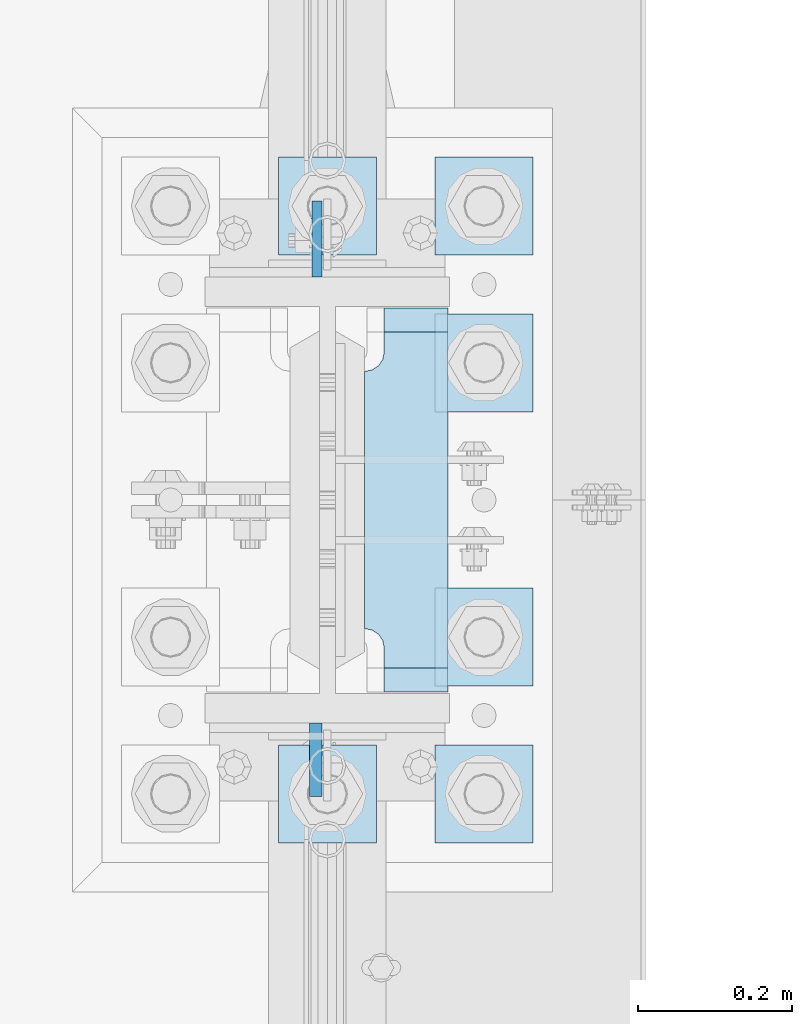
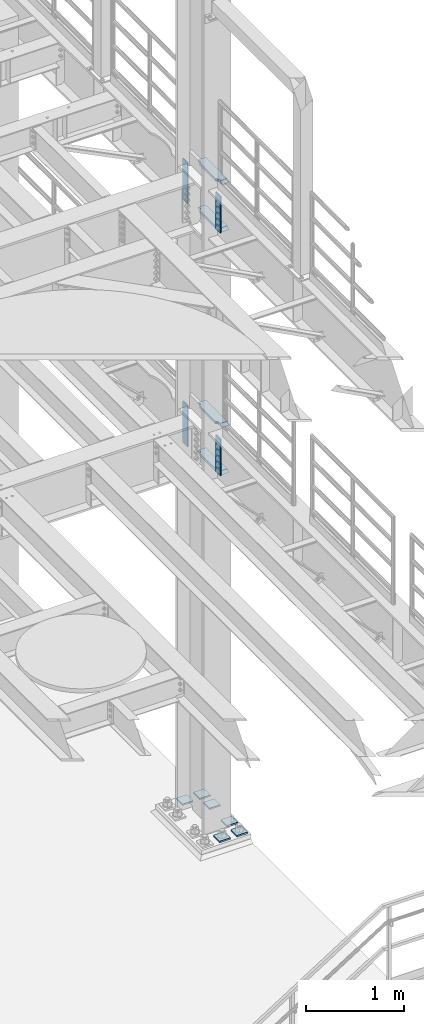
# One storey, part 1676 of 1876: 14 plates, 2 elements without a shape of their own.
"""IFC2X3 building model written with IfcOpenShell, lengths in millimetres."""

from ifc_helpers import new_model, si_unit, frame, origin_with_axes, place, context, subcontext, project, spatial, faceted_brep, material, type_object, element, aggregate, save


model = new_model("IFC2X3")

# Units and contexts
model_context = context("Model", 3, precision=1e-05, world=origin_with_axes())
body_context = subcontext(model_context, "Body", "Model", "MODEL_VIEW")
ifc_project = project(units=[si_unit("LENGTHUNIT", "METRE", prefix="MILLI"), si_unit("AREAUNIT", "SQUARE_METRE"), si_unit("VOLUMEUNIT", "CUBIC_METRE"), si_unit("MASSUNIT", "GRAM", prefix="KILO"), si_unit("TIMEUNIT", "SECOND"), si_unit("PLANEANGLEUNIT", "RADIAN"), si_unit("SOLIDANGLEUNIT", "STERADIAN"), si_unit("THERMODYNAMICTEMPERATUREUNIT", "DEGREE_CELSIUS"), si_unit("LUMINOUSINTENSITYUNIT", "LUMEN")], contexts=[model_context])

# Site, building, storey
site_placement = place(None, origin_with_axes())
site = spatial("IfcSite", under=ifc_project, at=site_placement, CompositionType="ELEMENT")
building_placement = place(site_placement, origin_with_axes())
building = spatial("IfcBuilding", under=site, at=building_placement, Name="Undefined", CompositionType="ELEMENT")
storey_placement = place(building_placement, origin_with_axes())
storey = spatial("IfcBuildingStorey", under=building, at=storey_placement, Name="Undefined", CompositionType="ELEMENT", Elevation=0.0)

# Assembly, plates
assembly_1_placement = place(storey_placement, origin_with_axes())
assembly_1 = element("IfcElementAssembly", 1, at=assembly_1_placement, inside=storey, Name="COLUMN", AssemblyPlace="NOTDEFINED", PredefinedType="RIGID_FRAME")
ifc_material_1 = material(Name="STEEL/A572-50")
plate_type_1 = type_object("IfcPlateType", PredefinedType="NOTDEFINED")
plate_1_placement = place(assembly_1_placement, frame((7606.50699987411, 1812.925, 8099.425), z_axis=(0.0, 1.0, 0.0), x_axis=(0.0, 0.0, -1.0)))
plate_1 = element("IfcPlate", 2, at=plate_1_placement, type_object=plate_type_1, material=ifc_material_1, Name="PLATE", context=body_context, shape_type="Brep", body=[
    faceted_brep([(0.0, -6.35000000000036, 0.0), (0.0, -6.34999999999991, 98.4250030517578), (0.0, 6.34999999999991, 98.4250030517578), (0.0, 6.35000000000036, 0.0), (514.349975585938, -6.35000000000036, 98.4250030517578), (514.349975585938, 6.35000000000036, 98.4250030517578), (514.349975585938, -6.35000000000036, 0.0), (514.349975585938, 6.35000000000036, 0.0)], [[[0, 1, 2, 3]], [[1, 4, 5, 2]], [[4, 6, 7, 5]], [[6, 0, 3, 7]], [[5, 7, 3, 2]], [[6, 4, 1, 0]]]),
])
plate_2_placement = place(assembly_1_placement, frame((7606.50699987411, 1812.925, 5076.825), z_axis=(0.0, 1.0, 0.0), x_axis=(0.0, 0.0, -1.0)))
plate_2 = element("IfcPlate", 3, at=plate_2_placement, type_object=plate_type_1, material=ifc_material_1, Name="PLATE", context=body_context, shape_type="Brep", body=[
    faceted_brep([(0.0, -6.35000000000036, 0.0), (0.0, -6.34999999999991, 98.4250030517578), (0.0, 6.34999999999991, 98.4250030517578), (0.0, 6.35000000000036, 0.0), (514.349975585938, -6.35000000000036, 98.4250030517578), (514.349975585938, 6.35000000000036, 98.4250030517578), (514.349975585938, -6.35000000000036, 0.0), (514.349975585938, 6.35000000000036, 0.0)], [[[0, 1, 2, 3]], [[1, 4, 5, 2]], [[4, 6, 7, 5]], [[6, 0, 3, 7]], [[5, 7, 3, 2]], [[6, 4, 1, 0]]]),
])
ifc_material_2 = material(Name="STEEL/A36")
plate_type_2 = type_object("IfcPlateType", PredefinedType="NOTDEFINED")
plate_3_placement = place(assembly_1_placement, frame((7604.91949987411, 1235.075, 8089.9), z_axis=(0.0, -1.0, 0.0), x_axis=(0.0, 0.0, -1.0)))
plate_3 = element("IfcPlate", 4, at=plate_3_placement, type_object=plate_type_2, material=ifc_material_2, Name="PLATE", context=body_context, shape_type="Brep", body=[
    faceted_brep([(0.0, -7.9375, 0.0), (0.0, -7.9375, 95.25), (0.0, 7.9375, 95.25), (0.0, 7.9375, 0.0), (457.200012207031, -7.9375, 95.25), (457.200012207031, 7.9375, 95.25), (457.200012207031, -7.9375, 0.0), (457.200012207031, 7.9375, 0.0)], [[[0, 1, 2, 3]], [[1, 4, 5, 2]], [[4, 6, 7, 5]], [[6, 0, 3, 7]], [[5, 7, 3, 2]], [[6, 4, 1, 0]]]),
])
plate_4_placement = place(assembly_1_placement, frame((7604.91949987411, 1235.075, 5067.3), z_axis=(0.0, -1.0, 0.0), x_axis=(0.0, 0.0, -1.0)))
plate_4 = element("IfcPlate", 5, at=plate_4_placement, type_object=plate_type_2, material=ifc_material_2, Name="PLATE", context=body_context, shape_type="Brep", body=[
    faceted_brep([(0.0, -7.9375, 0.0), (0.0, -7.9375, 95.25), (0.0, 7.9375, 95.25), (0.0, 7.9375, 0.0), (457.200012207031, -7.9375, 95.25), (457.200012207031, 7.9375, 95.25), (457.200012207031, -7.9375, 0.0), (457.200012207031, 7.9375, 0.0)], [[[0, 1, 2, 3]], [[1, 4, 5, 2]], [[4, 6, 7, 5]], [[6, 0, 3, 7]], [[5, 7, 3, 2]], [[6, 4, 1, 0]]]),
])
plate_type_3 = type_object("IfcPlateType", PredefinedType="NOTDEFINED")
plate_5_placement = place(assembly_1_placement, frame((7668.41875, 1773.2375, 7546.97501220703), z_axis=(0.0, -1.0, 0.0), x_axis=(1.0, 0.0, 0.0)))
plate_5 = element("IfcPlate", 6, at=plate_5_placement, type_object=plate_type_3, material=ifc_material_1, Name="PLATE", context=body_context, shape_type="Brep", body=[
    faceted_brep([(107.949996948242, -15.875, 498.475006103516), (107.949996948242, 15.875, 467.025007631571), (25.3999996185303, 15.875, 467.025007631571), (25.3999996185303, -15.875, 498.475006103516), (23.4665397733561, -15.875, 431.604843634198), (25.3999996185303, -15.875, 441.325002670288), (25.3999996185303, 15.875, 441.325002670288), (23.4665397733561, 15.875, 431.604843634198), (17.9605119724001, -15.875, 423.36449069789), (17.9605119724001, 15.875, 423.36449069789), (9.72015903609281, -15.875, 417.858462896934), (9.72015903609281, 15.875, 417.858462896934), (0.0, -15.875, 415.925003051758), (0.0, 15.875, 415.925003051758), (0.0, -15.875, 82.5500030517578), (0.0, 15.875, 82.5500030517578), (9.72015903609099, -15.875, 80.616543206582), (9.72015903609099, 15.875, 80.616543206582), (17.9605119723983, -15.875, 75.1105154056258), (17.9605119723983, 15.875, 75.1105154056258), (23.4665397733552, -15.875, 66.8701624693183), (23.4665397733552, 15.875, 66.8701624693183), (25.3999996185303, -15.875, 57.1500034332275), (25.3999996185303, 15.875, 57.1500034332275), (25.3999996185303, 15.875, 31.449998471945), (25.3999996185303, -15.875, 0.0), (107.949996948242, 15.875, 31.449998471945), (107.949996948242, -15.875, 0.0)], [[[0, 1, 2, 3]], [[4, 5, 6, 7]], [[8, 4, 7, 9]], [[10, 8, 9, 11]], [[12, 10, 11, 13]], [[14, 12, 13, 15]], [[16, 14, 15, 17]], [[18, 16, 17, 19]], [[20, 18, 19, 21]], [[22, 20, 21, 23]], [[22, 23, 24, 25]], [[26, 27, 25, 24]], [[5, 4, 8, 10, 12, 14, 16, 18, 20, 22, 25, 27, 0, 3]], [[6, 5, 3, 2]], [[26, 24, 23, 21, 19, 17, 15, 13, 11, 9, 7, 6, 2, 1]], [[27, 26, 1, 0]]]),
])
plate_6_placement = place(assembly_1_placement, frame((7668.41875, 1773.2375, 8137.525), z_axis=(0.0, -1.0, 0.0), x_axis=(1.0, 0.0, 0.0)))
plate_6 = element("IfcPlate", 7, at=plate_6_placement, type_object=plate_type_3, material=ifc_material_1, Name="PLATE", context=body_context, shape_type="Brep", body=[
    faceted_brep([(107.949996948242, -15.875, 498.475006103516), (107.949996948242, 15.875, 467.025007631571), (25.3999996185303, 15.875, 467.025007631571), (25.3999996185303, -15.875, 498.475006103516), (23.4665397733561, -15.875, 431.604843634198), (25.3999996185303, -15.875, 441.325002670288), (25.3999996185303, 15.875, 441.325002670288), (23.4665397733561, 15.875, 431.604843634198), (17.9605119724001, -15.875, 423.36449069789), (17.9605119724001, 15.875, 423.36449069789), (9.72015903609281, -15.875, 417.858462896934), (9.72015903609281, 15.875, 417.858462896934), (0.0, -15.875, 415.925003051758), (0.0, 15.875, 415.925003051758), (0.0, -15.875, 82.5500030517578), (0.0, 15.875, 82.5500030517578), (9.72015903609099, -15.875, 80.616543206582), (9.72015903609099, 15.875, 80.616543206582), (17.9605119723983, -15.875, 75.1105154056258), (17.9605119723983, 15.875, 75.1105154056258), (23.4665397733552, -15.875, 66.8701624693183), (23.4665397733552, 15.875, 66.8701624693183), (25.3999996185303, -15.875, 57.1500034332275), (25.3999996185303, 15.875, 57.1500034332275), (25.3999996185303, 15.875, 31.449998471945), (25.3999996185303, -15.875, 0.0), (107.949996948242, 15.875, 31.449998471945), (107.949996948242, -15.875, 0.0)], [[[0, 1, 2, 3]], [[4, 5, 6, 7]], [[8, 4, 7, 9]], [[10, 8, 9, 11]], [[12, 10, 11, 13]], [[14, 12, 13, 15]], [[16, 14, 15, 17]], [[18, 16, 17, 19]], [[20, 18, 19, 21]], [[22, 20, 21, 23]], [[22, 23, 24, 25]], [[26, 27, 25, 24]], [[5, 4, 8, 10, 12, 14, 16, 18, 20, 22, 25, 27, 0, 3]], [[6, 5, 3, 2]], [[26, 24, 23, 21, 19, 17, 15, 13, 11, 9, 7, 6, 2, 1]], [[27, 26, 1, 0]]]),
])
plate_7_placement = place(assembly_1_placement, frame((7668.41875, 1773.2375, 4524.37497558594), z_axis=(0.0, -1.0, 0.0), x_axis=(1.0, 0.0, 0.0)))
plate_7 = element("IfcPlate", 8, at=plate_7_placement, type_object=plate_type_3, material=ifc_material_1, Name="PLATE", context=body_context, shape_type="Brep", body=[
    faceted_brep([(107.949996948242, -15.875, 498.475006103516), (107.949996948242, 15.875, 467.025007631571), (25.3999996185303, 15.875, 467.025007631571), (25.3999996185303, -15.875, 498.475006103516), (23.4665397733561, -15.875, 431.604843634198), (25.3999996185303, -15.875, 441.325002670288), (25.3999996185303, 15.875, 441.325002670288), (23.4665397733561, 15.875, 431.604843634198), (17.9605119724001, -15.875, 423.36449069789), (17.9605119724001, 15.875, 423.36449069789), (9.72015903609281, -15.875, 417.858462896934), (9.72015903609281, 15.875, 417.858462896934), (0.0, -15.875, 415.925003051758), (0.0, 15.875, 415.925003051758), (0.0, -15.875, 82.5500030517578), (0.0, 15.875, 82.5500030517578), (9.72015903609099, -15.875, 80.616543206582), (9.72015903609099, 15.875, 80.616543206582), (17.9605119723983, -15.875, 75.1105154056258), (17.9605119723983, 15.875, 75.1105154056258), (23.4665397733552, -15.875, 66.8701624693183), (23.4665397733552, 15.875, 66.8701624693183), (25.3999996185303, -15.875, 57.1500034332275), (25.3999996185303, 15.875, 57.1500034332275), (25.3999996185303, 15.875, 31.449998471945), (25.3999996185303, -15.875, 0.0), (107.949996948242, 15.875, 31.449998471945), (107.949996948242, -15.875, 0.0)], [[[0, 1, 2, 3]], [[4, 5, 6, 7]], [[8, 4, 7, 9]], [[10, 8, 9, 11]], [[12, 10, 11, 13]], [[14, 12, 13, 15]], [[16, 14, 15, 17]], [[18, 16, 17, 19]], [[20, 18, 19, 21]], [[22, 20, 21, 23]], [[22, 23, 24, 25]], [[26, 27, 25, 24]], [[5, 4, 8, 10, 12, 14, 16, 18, 20, 22, 25, 27, 0, 3]], [[6, 5, 3, 2]], [[26, 24, 23, 21, 19, 17, 15, 13, 11, 9, 7, 6, 2, 1]], [[27, 26, 1, 0]]]),
])
plate_8_placement = place(assembly_1_placement, frame((7668.41875, 1773.2375, 5114.925), z_axis=(0.0, -1.0, 0.0), x_axis=(1.0, 0.0, 0.0)))
plate_8 = element("IfcPlate", 9, at=plate_8_placement, type_object=plate_type_3, material=ifc_material_1, Name="PLATE", context=body_context, shape_type="Brep", body=[
    faceted_brep([(107.949996948242, -15.875, 498.475006103516), (107.949996948242, 15.875, 467.025007631571), (25.3999996185303, 15.875, 467.025007631571), (25.3999996185303, -15.875, 498.475006103516), (23.4665397733561, -15.875, 431.604843634198), (25.3999996185303, -15.875, 441.325002670288), (25.3999996185303, 15.875, 441.325002670288), (23.4665397733561, 15.875, 431.604843634198), (17.9605119724001, -15.875, 423.36449069789), (17.9605119724001, 15.875, 423.36449069789), (9.72015903609281, -15.875, 417.858462896934), (9.72015903609281, 15.875, 417.858462896934), (0.0, -15.875, 415.925003051758), (0.0, 15.875, 415.925003051758), (0.0, -15.875, 82.5500030517578), (0.0, 15.875, 82.5500030517578), (9.72015903609099, -15.875, 80.616543206582), (9.72015903609099, 15.875, 80.616543206582), (17.9605119723983, -15.875, 75.1105154056258), (17.9605119723983, 15.875, 75.1105154056258), (23.4665397733552, -15.875, 66.8701624693183), (23.4665397733552, 15.875, 66.8701624693183), (25.3999996185303, -15.875, 57.1500034332275), (25.3999996185303, 15.875, 57.1500034332275), (25.3999996185303, 15.875, 31.449998471945), (25.3999996185303, -15.875, 0.0), (107.949996948242, 15.875, 31.449998471945), (107.949996948242, -15.875, 0.0)], [[[0, 1, 2, 3]], [[4, 5, 6, 7]], [[8, 4, 7, 9]], [[10, 8, 9, 11]], [[12, 10, 11, 13]], [[14, 12, 13, 15]], [[16, 14, 15, 17]], [[18, 16, 17, 19]], [[20, 18, 19, 21]], [[22, 20, 21, 23]], [[22, 23, 24, 25]], [[26, 27, 25, 24]], [[5, 4, 8, 10, 12, 14, 16, 18, 20, 22, 25, 27, 0, 3]], [[6, 5, 3, 2]], [[26, 24, 23, 21, 19, 17, 15, 13, 11, 9, 7, 6, 2, 1]], [[27, 26, 1, 0]]]),
])
aggregate(assembly_1, [plate_3, plate_1, plate_5, plate_6, plate_2, plate_7, plate_8, plate_4])

assembly_2_placement = place(storey_placement, origin_with_axes())
assembly_2 = element("IfcElementAssembly", 10, at=assembly_2_placement, inside=storey, Name="TEMPLATE", AssemblyPlace="NOTDEFINED", PredefinedType="RIGID_FRAME")
plate_type_4 = type_object("IfcPlateType", PredefinedType="NOTDEFINED")
plate_9_placement = place(assembly_2_placement, frame((7683.5, 1206.5, 104.775), z_axis=(-1.0, 0.0, 0.0), x_axis=(0.0, -1.0, 0.0)))
plate_9 = element("IfcPlate", 11, at=plate_9_placement, type_object=plate_type_4, material=ifc_material_1, Name="PLATE WASHER", context=body_context, shape_type="Brep", body=[
    faceted_brep([(-9.09494701772928e-13, -9.525, -1.81898940354586e-12), (0.0, -9.52500000000001, 127.0), (0.0, 9.52500000000001, 127.0), (-9.09494701772928e-13, 9.525, -1.81898940354586e-12), (127.0, -9.52500000000001, 127.0), (127.0, 9.52500000000001, 127.0), (127.0, -9.52500000000001, 0.0), (127.0, 9.52500000000001, 0.0)], [[[0, 1, 2, 3]], [[1, 4, 5, 2]], [[4, 6, 7, 5]], [[6, 0, 3, 7]], [[5, 7, 3, 2]], [[6, 4, 1, 0]]]),
])
plate_10_placement = place(assembly_2_placement, frame((7886.7, 1206.5, 104.775), z_axis=(-1.0, 0.0, 0.0), x_axis=(0.0, -1.0, 0.0)))
plate_10 = element("IfcPlate", 12, at=plate_10_placement, type_object=plate_type_4, material=ifc_material_1, Name="PLATE WASHER", context=body_context, shape_type="Brep", body=[
    faceted_brep([(-9.09494701772928e-13, -9.525, -1.81898940354586e-12), (0.0, -9.52500000000001, 127.0), (0.0, 9.52500000000001, 127.0), (-9.09494701772928e-13, 9.525, -1.81898940354586e-12), (127.0, -9.52500000000001, 127.0), (127.0, 9.52500000000001, 127.0), (127.0, -9.52500000000001, 0.0), (127.0, 9.52500000000001, 0.0)], [[[0, 1, 2, 3]], [[1, 4, 5, 2]], [[4, 6, 7, 5]], [[6, 0, 3, 7]], [[5, 7, 3, 2]], [[6, 4, 1, 0]]]),
])
plate_11_placement = place(assembly_2_placement, frame((7886.7, 1409.7, 104.775), z_axis=(-1.0, 0.0, 0.0), x_axis=(0.0, -1.0, 0.0)))
plate_11 = element("IfcPlate", 13, at=plate_11_placement, type_object=plate_type_4, material=ifc_material_1, Name="PLATE WASHER", context=body_context, shape_type="Brep", body=[
    faceted_brep([(-9.09494701772928e-13, -9.525, -1.81898940354586e-12), (0.0, -9.52500000000001, 127.0), (0.0, 9.52500000000001, 127.0), (-9.09494701772928e-13, 9.525, -1.81898940354586e-12), (127.0, -9.52500000000001, 127.0), (127.0, 9.52500000000001, 127.0), (127.0, -9.52500000000001, 0.0), (127.0, 9.52500000000001, 0.0)], [[[0, 1, 2, 3]], [[1, 4, 5, 2]], [[4, 6, 7, 5]], [[6, 0, 3, 7]], [[5, 7, 3, 2]], [[6, 4, 1, 0]]]),
])
plate_12_placement = place(assembly_2_placement, frame((7886.7, 1765.3, 104.775), z_axis=(-1.0, 0.0, 0.0), x_axis=(0.0, -1.0, 0.0)))
plate_12 = element("IfcPlate", 14, at=plate_12_placement, type_object=plate_type_4, material=ifc_material_1, Name="PLATE WASHER", context=body_context, shape_type="Brep", body=[
    faceted_brep([(-9.09494701772928e-13, -9.525, -1.81898940354586e-12), (0.0, -9.52500000000001, 127.0), (0.0, 9.52500000000001, 127.0), (-9.09494701772928e-13, 9.525, -1.81898940354586e-12), (127.0, -9.52500000000001, 127.0), (127.0, 9.52500000000001, 127.0), (127.0, -9.52500000000001, 0.0), (127.0, 9.52500000000001, 0.0)], [[[0, 1, 2, 3]], [[1, 4, 5, 2]], [[4, 6, 7, 5]], [[6, 0, 3, 7]], [[5, 7, 3, 2]], [[6, 4, 1, 0]]]),
])
plate_13_placement = place(assembly_2_placement, frame((7683.5, 1968.5, 104.775), z_axis=(-1.0, 0.0, 0.0), x_axis=(0.0, -1.0, 0.0)))
plate_13 = element("IfcPlate", 15, at=plate_13_placement, type_object=plate_type_4, material=ifc_material_1, Name="PLATE WASHER", context=body_context, shape_type="Brep", body=[
    faceted_brep([(-9.09494701772928e-13, -9.525, -1.81898940354586e-12), (0.0, -9.52500000000001, 127.0), (0.0, 9.52500000000001, 127.0), (-9.09494701772928e-13, 9.525, -1.81898940354586e-12), (127.0, -9.52500000000001, 127.0), (127.0, 9.52500000000001, 127.0), (127.0, -9.52500000000001, 0.0), (127.0, 9.52500000000001, 0.0)], [[[0, 1, 2, 3]], [[1, 4, 5, 2]], [[4, 6, 7, 5]], [[6, 0, 3, 7]], [[5, 7, 3, 2]], [[6, 4, 1, 0]]]),
])
plate_14_placement = place(assembly_2_placement, frame((7886.7, 1968.5, 104.775), z_axis=(-1.0, 0.0, 0.0), x_axis=(0.0, -1.0, 0.0)))
plate_14 = element("IfcPlate", 16, at=plate_14_placement, type_object=plate_type_4, material=ifc_material_1, Name="PLATE WASHER", context=body_context, shape_type="Brep", body=[
    faceted_brep([(-9.09494701772928e-13, -9.525, -1.81898940354586e-12), (0.0, -9.52500000000001, 127.0), (0.0, 9.52500000000001, 127.0), (-9.09494701772928e-13, 9.525, -1.81898940354586e-12), (127.0, -9.52500000000001, 127.0), (127.0, 9.52500000000001, 127.0), (127.0, -9.52500000000001, 0.0), (127.0, 9.52500000000001, 0.0)], [[[0, 1, 2, 3]], [[1, 4, 5, 2]], [[4, 6, 7, 5]], [[6, 0, 3, 7]], [[5, 7, 3, 2]], [[6, 4, 1, 0]]]),
])
aggregate(assembly_2, [plate_9, plate_10, plate_11, plate_12, plate_13, plate_14])

save(model, "model.ifc")
